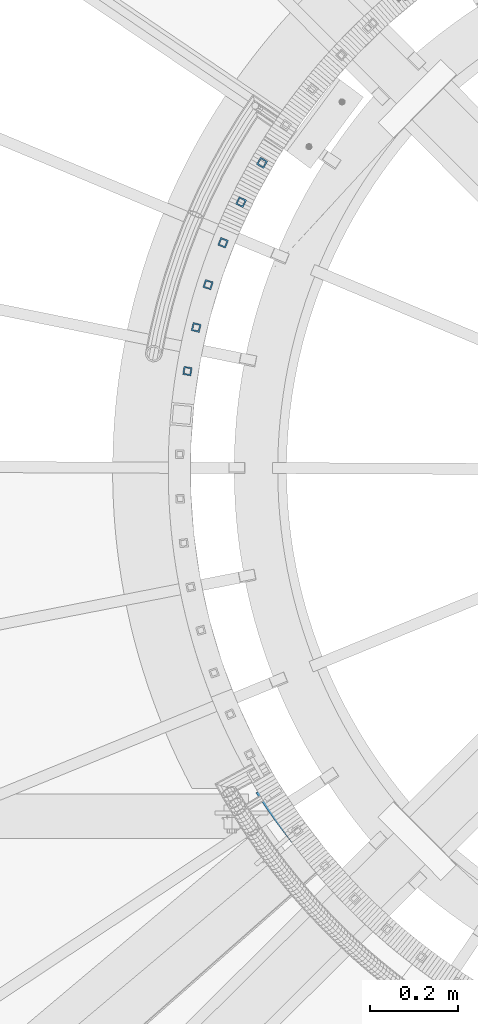
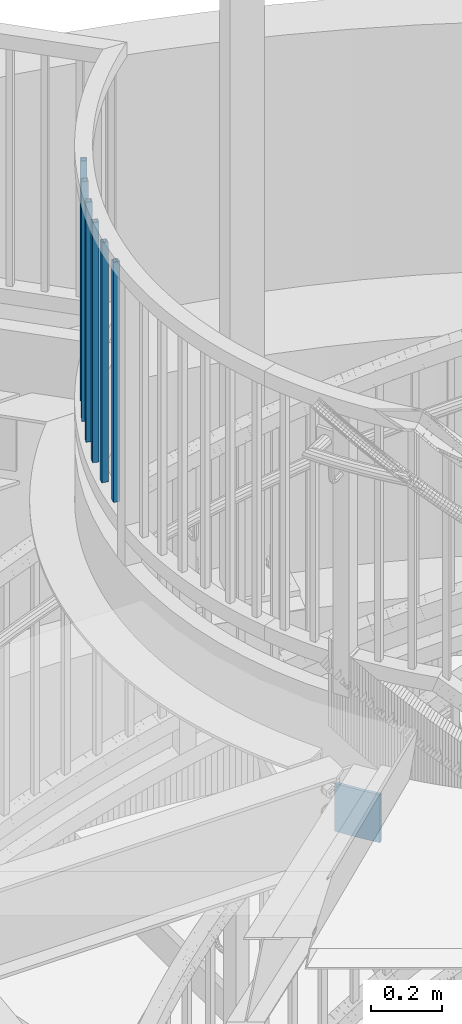
# One storey, part 476 of 975: 7 beams.
"""IFC2X3 building model written with IfcOpenShell, lengths in millimetres."""

import ifcopenshell
import ifcopenshell.guid

model = None  # the IFC model being written
_history = None  # IfcOwnerHistory: only IFC2X3 demands one
_inside = {}  # id of a spatial element -> (the spatial element, [elements in it])
_under = {}  # id of a project, library or spatial element -> (it, [spatial elements below it])
_declared = {}  # id of a project -> (the project, [libraries it declares])
_typed = {}  # id of a type object -> (the type object, [elements of that type])
_made_of = {}  # id of a material, layer set ... -> (it, [elements and type objects made of it])


def new_model(schema):
    """Start an empty IFC model of exactly this schema.

    Asked for "IFC4X3", IfcOpenShell would pick the latest addendum, in which some entities
    have other attributes; the version numbers below select the first issue.
    IFC2X3 requires an IfcOwnerHistory on every rooted entity: one is made here for all.
    """
    global model, _history
    if schema == "IFC4X3":
        model = ifcopenshell.file(schema_version=(4, 3, 0, 0))
    else:
        model = ifcopenshell.file(schema=schema)
    _inside.clear()
    _under.clear()
    _declared.clear()
    _typed.clear()
    _made_of.clear()
    _history = None
    if model.schema == "IFC2X3":
        org = make("IfcOrganization", Name="unknown")
        user = make(
            "IfcPersonAndOrganization",
            ThePerson=make("IfcPerson", FamilyName="unknown"),
            TheOrganization=org,
        )
        app = make(
            "IfcApplication",
            ApplicationDeveloper=org,
            Version="unknown",
            ApplicationFullName="unknown",
            ApplicationIdentifier="unknown",
        )
        _history = make(
            "IfcOwnerHistory",
            OwningUser=user,
            OwningApplication=app,
            ChangeAction="ADDED",
            CreationDate=0,
        )
    return model


def make(cls, **values):
    """One entity of the class cls with the attributes given. An attribute that is None is left unset."""
    return model.create_entity(
        cls, **{name: value for name, value in values.items() if value is not None}
    )


def rooted(cls, **values):
    """An entity with a GlobalId (a new one), such as an element, a storey or a relation."""
    return make(cls, GlobalId=ifcopenshell.guid.new(), OwnerHistory=_history, **values)


def si_unit(unit_type, name, prefix=None):
    """IfcSIUnit, for example si_unit("LENGTHUNIT", "METRE", prefix="MILLI")."""
    return make("IfcSIUnit", UnitType=unit_type, Prefix=prefix, Name=name)


def assignment(units):
    """IfcUnitAssignment: the units of a project."""
    return None if units is None else make("IfcUnitAssignment", Units=units)


def point(xyz):
    """IfcCartesianPoint."""
    return None if xyz is None else make("IfcCartesianPoint", Coordinates=xyz)


def direction(xyz):
    """IfcDirection."""
    return None if xyz is None else make("IfcDirection", DirectionRatios=xyz)


def frame(location, z_axis=None, x_axis=None):
    """IfcAxis2Placement3D, a coordinate frame: its origin and axes. An axis left out is left unset."""
    return make(
        "IfcAxis2Placement3D",
        Location=point(location),
        Axis=direction(z_axis),
        RefDirection=direction(x_axis),
    )


def origin_with_axes():
    """The frame at (0, 0, 0) with the z axis (0, 0, 1) and the x axis (1, 0, 0) written out."""
    return frame((0.0, 0.0, 0.0), z_axis=(0.0, 0.0, 1.0), x_axis=(1.0, 0.0, 0.0))


def place(relative_to, where):
    """IfcLocalPlacement: puts the frame where relative to a parent placement (None: the world)."""
    return make(
        "IfcLocalPlacement", PlacementRelTo=relative_to, RelativePlacement=where
    )


def context(
    kind, dimensions, precision=None, world=None, true_north=None, identifier=None
):
    """IfcGeometricRepresentationContext, for example the 3D "Model" context."""
    return make(
        "IfcGeometricRepresentationContext",
        ContextIdentifier=identifier,
        ContextType=kind,
        CoordinateSpaceDimension=dimensions,
        Precision=precision,
        WorldCoordinateSystem=world,
        TrueNorth=true_north,
    )


def subcontext(parent, identifier, kind, view, scale=None):
    """IfcGeometricRepresentationSubContext, for example "Body" below "Model"."""
    return make(
        "IfcGeometricRepresentationSubContext",
        ContextIdentifier=identifier,
        ContextType=kind,
        ParentContext=parent,
        TargetScale=scale,
        TargetView=view,
    )


def project(units=None, contexts=None):
    """IfcProject with its units and contexts."""
    return rooted(
        "IfcProject",
        Name="project",
        RepresentationContexts=contexts,
        UnitsInContext=assignment(units),
    )


def spatial(cls, under=None, at=None, **own):
    """A site, building, storey or space (cls), placed at a placement, below another one or the project."""
    s = rooted(cls, ObjectPlacement=at, **own)
    if under is not None:
        _under.setdefault(under.id(), (under, []))[1].append(s)
    return s


def faces_of(points, faces, orient=None, outer=None):
    """IfcFace entities. A face is a list of loops; a loop is a list of indices into points, from 0.

    orient and outer hold one flag for each loop. By default every Orientation is true, the
    first loop of a face is its IfcFaceOuterBound and the others are IfcFaceBound.
    """
    made = []
    for i, loops in enumerate(faces):
        bounds = []
        for j, loop in enumerate(loops):
            is_outer = j == 0 if outer is None else outer[i][j]
            bounds.append(
                make(
                    "IfcFaceOuterBound" if is_outer else "IfcFaceBound",
                    Bound=make("IfcPolyLoop", Polygon=[points[k] for k in loop]),
                    Orientation=True if orient is None else orient[i][j],
                )
            )
        made.append(make("IfcFace", Bounds=bounds))
    return made


def faceted_brep(points, faces, orient=None, outer=None, voids=None):
    """IfcFacetedBrep: a solid bounded by flat faces; with voids (closed shells), ...WithVoids."""
    shared = [point(p) for p in points]
    hull = make("IfcClosedShell", CfsFaces=faces_of(shared, faces, orient, outer))
    if voids is None:
        return make("IfcFacetedBrep", Outer=hull)
    return make(
        "IfcFacetedBrepWithVoids",
        Outer=hull,
        Voids=[
            make(cls, CfsFaces=faces_of(shared, fs, o, b)) for cls, fs, o, b in voids
        ],
    )


def shape(context_of_items, identifier, shape_type, items):
    """IfcShapeRepresentation: the items that make up one representation, for example the "Body"."""
    return make(
        "IfcShapeRepresentation",
        ContextOfItems=context_of_items,
        RepresentationIdentifier=identifier,
        RepresentationType=shape_type,
        Items=items,
    )


def material(Name=None, Category=None):
    """IfcMaterial."""
    return make("IfcMaterial", Name=Name, Category=Category)


def made_of(thing, what):
    """Note that an element or type object is made of a material, layer set ...; save() writes the relation."""
    if what is not None:
        _made_of.setdefault(what.id(), (what, []))[1].append(thing)
    return thing


def type_object(cls, material=None, **own):
    """A type object (cls), such as IfcWallType, which elements share."""
    return made_of(rooted(cls, **own), material)


def element(
    cls,
    number,
    at=None,
    inside=None,
    cuts=None,
    type_object=None,
    material=None,
    context=None,
    identifier="Body",
    shape_type=None,
    held_by="IfcProductDefinitionShape",
    body=None,
    shapes=None,
    **own,
):
    """One element of the class cls, such as IfcWall. Its Tag is "e" and its number.

    at: its placement. inside: the storey or other place that contains it. cuts: it is an
    opening in that element (IfcRelVoidsElement). A single representation is given by context,
    identifier, shape_type and body (its items); several are given by shapes. held_by: the class
    of the entity that holds the representations. save() writes the other relations.
    """
    e = rooted(cls, Tag="e%d" % number, ObjectPlacement=at, **own)
    if body is not None:
        shapes = [shape(context, identifier, shape_type, body)]
    if shapes is not None:
        e.Representation = make(held_by, Representations=shapes)
    if inside is not None:
        _inside.setdefault(inside.id(), (inside, []))[1].append(e)
    if cuts is not None:
        rooted(
            "IfcRelVoidsElement", RelatingBuildingElement=cuts, RelatedOpeningElement=e
        )
    if type_object is not None:
        _typed.setdefault(type_object.id(), (type_object, []))[1].append(e)
    return made_of(e, material)


def aggregate(whole, parts):
    """IfcRelAggregates: a whole, such as a stair, and the parts it consists of."""
    return rooted("IfcRelAggregates", RelatingObject=whole, RelatedObjects=parts)


def save(model, path):
    """Write the relations noted so far, then the file.

    IfcRelAggregates (storeys below a building ...), IfcRelContainedInSpatialStructure (elements
    in a storey), IfcRelDefinesByType, IfcRelAssociatesMaterial and IfcRelDeclares: one each for
    every whole, place, type object, material and project.
    """
    for whole, parts in _under.values():
        aggregate(whole, parts)
    for where, things in _inside.values():
        rooted(
            "IfcRelContainedInSpatialStructure",
            RelatedElements=things,
            RelatingStructure=where,
        )
    for kind, things in _typed.values():
        rooted("IfcRelDefinesByType", RelatedObjects=things, RelatingType=kind)
    for what, things in _made_of.values():
        rooted("IfcRelAssociatesMaterial", RelatedObjects=things, RelatingMaterial=what)
    for by, libraries in _declared.values():
        rooted("IfcRelDeclares", RelatingContext=by, RelatedDefinitions=libraries)
    model.write(path)


model = new_model("IFC2X3")

# Units and contexts
model_context = context("Model", 3, precision=1e-05, world=origin_with_axes())
body_context = subcontext(model_context, "Body", "Model", "MODEL_VIEW")
ifc_project = project(units=[si_unit("LENGTHUNIT", "METRE", prefix="MILLI"), si_unit("AREAUNIT", "SQUARE_METRE"), si_unit("VOLUMEUNIT", "CUBIC_METRE"), si_unit("MASSUNIT", "GRAM", prefix="KILO"), si_unit("TIMEUNIT", "SECOND"), si_unit("PLANEANGLEUNIT", "RADIAN"), si_unit("SOLIDANGLEUNIT", "STERADIAN"), si_unit("THERMODYNAMICTEMPERATUREUNIT", "DEGREE_CELSIUS"), si_unit("LUMINOUSINTENSITYUNIT", "LUMEN")], contexts=[model_context])

# Site, building, storey
site_placement = place(None, origin_with_axes())
site = spatial("IfcSite", under=ifc_project, at=site_placement, CompositionType="ELEMENT")
building_placement = place(site_placement, origin_with_axes())
building = spatial("IfcBuilding", under=site, at=building_placement, Name="Undefined", CompositionType="ELEMENT")
storey_placement = place(building_placement, origin_with_axes())
storey = spatial("IfcBuildingStorey", under=building, at=storey_placement, Name="Undefined", CompositionType="ELEMENT", Elevation=0.0)

# Beams
ifc_material_1 = material()
beam_type_1 = type_object("IfcBeamType", Name="HSS3/4X3/4X.120_TUBES", PredefinedType="NOTDEFINED")
for number, where, z_axis, x_axis, name in (
    (1, (33526.2036362161, 4104.66952004517, 4279.9), (-0.864920583602522, 0.501908740769348, 0.0), (0.0, 0.0, 1.0), "PICKET"),
    (2, (33478.4562580799, 4015.03159745493, 4279.9), (-0.899104743728722, 0.437733548867926, 0.0), (0.0, 0.0, 1.0), "PICKET"),
    (3, (33437.34853009, 3922.16112859848, 4279.9), (-0.928535325998714, 0.371244054999486, 0.0), (0.0, 0.0, 1.0), "PICKET"),
    (4, (33403.0977892671, 3826.54912077631, 4279.9), (-0.953056730716079, 0.302791789909797, 0.0), (0.0, 0.0, 1.0), "PICKET"),
    (5, (33375.8851197102, 3728.70107582034, 4279.9), (-0.972539313394312, 0.232738660094363, 0.0), (0.0, 0.0, 1.0), "PICKET"),
    (6, (33355.8543951191, 3629.13431752426, 4279.9), (-0.986880069056733, 0.161455038009282, 0.0), (0.0, 0.0, 1.0), "PICKET"),
):
    element("IfcBeam", number, at=place(storey_placement, frame(where, z_axis=z_axis, x_axis=x_axis)), inside=storey, type_object=beam_type_1, material=ifc_material_1, Name=name, ObjectType="HSS3/4X3/4X.120_TUBES", context=body_context, shape_type="Brep", body=[
        faceted_brep([(0.0, 6.34999999998763, -6.34999999998763), (0.0, -6.35000000000582, -6.34999999998763), (825.49997943247, -6.35000000000582, -6.34999999998763), (825.49997943247, 6.34999999998763, -6.34999999998763), (0.0, -6.34999999998763, 6.34999999998763), (825.49997943247, -6.34999999998763, 6.34999999998763), (0.0, 6.35000000000946, 6.34999999998763), (825.49997943247, 6.35000000000946, 6.34999999998763), (0.0, 9.52499999997963, -9.52499999997963), (0.0, 9.52500000000873, 9.5249999999869), (825.49997943247, 9.52500000000873, 9.5249999999869), (825.49997943247, 9.52499999997963, -9.52499999997963), (0.0, -9.52499999997963, 9.52499999998327), (825.49997943247, -9.52499999997963, 9.52499999998327), (0.0, -9.52500000000873, -9.5249999999869), (825.49997943247, -9.52500000000873, -9.5249999999869)], [[[0, 1, 2, 3]], [[1, 4, 5, 2]], [[4, 6, 7, 5]], [[6, 0, 3, 7]], [[8, 9, 10, 11]], [[9, 12, 13, 10]], [[12, 14, 15, 13]], [[14, 8, 11, 15]], [[13, 15, 11, 10], [5, 7, 3, 2]], [[14, 12, 9, 8], [6, 4, 1, 0]]]),
    ])
ifc_material_2 = material(Name="STEEL/A36")
beam_type_2 = type_object("IfcBeamType", PredefinedType="NOTDEFINED")
beam_placement = place(storey_placement, frame((33598.4438526061, 2554.79808914706, 3752.87588265217), z_axis=(0.0, 0.0, 1.0), x_axis=(-0.58585209482599, 0.810417992759292, 0.0)))
element("IfcBeam", 7, at=beam_placement, inside=storey, type_object=beam_type_2, material=ifc_material_2, Name="PLATE", context=body_context, shape_type="Brep", body=[
    faceted_brep([(-0.241980966413394, 4.75634854293821, -82.5500000000002), (-0.241980966413394, 4.75634854293821, 82.5500000000002), (2.14033713367462, 4.87549213239618, 82.5500000000002), (2.14033713367462, 4.87549213239618, -82.5500000000002), (0.241980966406118, -4.75634854294913, 82.5500000000002), (0.241980966406118, -4.75634854294913, -82.5500000000002), (2.60790699908466, -4.63802474734985, -82.5500000000002), (2.60790699908466, -4.63802474734985, 82.5500000000002), (4.52285699369168, 4.99053056750927, 82.5500000000002), (4.52285699369168, 4.99053056750927, -82.5500000000002), (4.97403340342862, -4.52377785967474, -82.5500000000002), (4.97403340342862, -4.52377785967474, 82.5500000000002), (6.9055715397335, 5.10146350670766, 82.5500000000002), (6.9055715397335, 5.10146350670766, -82.5500000000002), (7.34035315422079, -4.41360821913986, -82.5500000000002), (7.34035315422079, -4.41360821913986, 82.5500000000002), (9.28847369732466, 5.20829062062694, 82.5500000000002), (9.28847369732466, 5.20829062062694, -82.5500000000002), (9.70685922566554, -4.30751615283589, -82.5500000000002), (9.70685922566554, -4.30751615283589, 82.5500000000002), (11.6715563914368, 5.31101159209356, 82.5500000000002), (11.6715563914368, 5.31101159209356, -82.5500000000002), (12.0735445913961, -4.20550197577904, -82.5500000000002), (12.0735445913961, -4.20550197577904, 82.5500000000002), (14.0548125464848, 5.40962611609939, 82.5500000000002), (14.0548125464848, 5.40962611609939, -82.5500000000002), (14.4404022245362, -4.10756599083834, -82.5500000000002), (14.4404022245362, -4.10756599083834, 82.5500000000002), (16.4382350863889, 5.50413389987807, 82.5500000000002), (16.4382350863889, 5.50413389987807, -82.5500000000002), (16.8074250976861, -4.01370848880106, -82.5500000000002), (16.8074250976861, -4.01370848880106, 82.5500000000002), (18.8218169345746, 5.59453466281411, 82.5500000000002), (18.8218169345746, 5.59453466281411, -82.5500000000002), (19.1746061829544, -3.92392974834729, -82.5500000000002), (19.1746061829544, -3.92392974834729, 82.5500000000002), (21.2055510139799, 5.6808281364938, 82.5500000000002), (21.2055510139799, 5.6808281364938, -82.5500000000002), (21.5419384519882, -3.83823003602811, -82.5500000000002), (21.5419384519882, -3.83823003602811, 82.5500000000002), (23.5894302471097, 5.76301406471612, 82.5500000000002), (23.5894302471097, 5.76301406471612, -82.5500000000002), (23.9094148759759, -3.75660960628738, -82.5500000000002), (23.9094148759759, -3.75660960628738, 82.5500000000002), (25.9734475560181, 5.84109220345999, 82.5500000000002), (25.9734475560181, 5.84109220345999, -82.5500000000002), (26.2770284256876, -3.67906870147999, -82.5500000000002), (26.2770284256876, -3.67906870147999, 82.5500000000002), (28.357595862366, 5.91506232090251, 82.5500000000002), (28.357595862366, 5.91506232090251, -82.5500000000002), (28.6447720714787, -3.60560755181359, -82.5500000000002), (28.6447720714787, -3.60560755181359, 82.5500000000002), (30.7418680874143, 5.98492419742615, 82.5500000000002), (30.7418680874143, 5.98492419742615, -82.5500000000002), (31.0126387833188, -3.53622637541048, -82.5500000000002), (31.0126387833188, -3.53622637541048, 82.5500000000002), (33.1262571520601, 6.05067762559702, 82.5500000000002), (33.1262571520601, 6.05067762559702, -82.5500000000002), (33.3806215308214, -3.47092537826757, -82.5500000000002), (33.3806215308214, -3.47092537826757, 82.5500000000002), (35.5107559768585, 6.11232241019388, 82.5500000000002), (35.5107559768585, 6.11232241019388, -82.5500000000002), (35.7487132832466, -3.40970475426366, -82.5500000000002), (35.7487132832466, -3.40970475426366, 82.5500000000002), (37.8953574820298, 6.1698583681864, 82.5500000000002), (37.8953574820298, 6.1698583681864, -82.5500000000002), (38.1169070095275, -3.35256468517036, -82.5500000000002), (38.1169070095275, -3.35256468517036, 82.5500000000002), (40.2800545874961, 6.22328532874599, 82.5500000000002), (40.2800545874961, 6.22328532874599, -82.5500000000002), (40.4851956783059, -3.29950534064847, -82.5500000000002), (40.4851956783059, -3.29950534064847, 82.5500000000002), (42.6648402128922, 6.27260313324587, 82.5500000000002), (42.6648402128922, 6.27260313324587, -82.5500000000002), (42.853572257929, -3.25052687822972, -82.5500000000002), (42.853572257929, -3.25052687822972, 82.5500000000002), (45.049707277587, 6.31781163525011, 82.5500000000002), (45.049707277587, 6.31781163525011, -82.5500000000002), (45.2220297164931, -3.20562944333869, -82.5500000000002), (45.2220297164931, -3.20562944333869, 82.5500000000002), (47.4346487007169, 6.35891070053549, 82.5500000000002), (47.4346487007169, 6.35891070053549, -82.5500000000002), (47.5905610218506, -3.1648131692782, -82.5500000000002), (47.5905610218506, -3.1648131692782, 82.5500000000002), (49.819657401189, 6.39590020708056, 82.5500000000002), (49.819657401189, 6.39590020708056, -82.5500000000002), (49.9591591416392, -3.12807817722933, -82.5500000000002), (49.9591591416392, -3.12807817722933, 82.5500000000002), (52.2047262977212, 6.4287800450511, 82.5500000000002), (52.2047262977212, 6.4287800450511, -82.5500000000002), (52.3278170432859, -3.09542457626594, -82.5500000000002), (52.3278170432859, -3.09542457626594, 82.5500000000002), (54.5898483088276, 6.45755011682559, 82.5500000000002), (54.5898483088276, 6.45755011682559, -82.5500000000002), (54.6965276940537, -3.06685246334018, -82.5500000000002), (54.6965276940537, -3.06685246334018, 82.5500000000002), (56.9750163529061, 6.48221033699156, 82.5500000000002), (56.9750163529061, 6.48221033699156, -82.5500000000002), (57.0652840610419, -3.04236192328608, -82.5500000000002), (57.0652840610419, -3.04236192328608, 82.5500000000002), (59.3602233481761, 6.50276063232377, 82.5500000000002), (59.3602233481761, 6.50276063232377, -82.5500000000002), (59.4340791112154, -3.02195302880864, -82.5500000000002), (59.4340791112154, -3.02195302880864, 82.5500000000002), (61.7454622127661, 6.51920094180605, 82.5500000000002), (61.7454622127661, 6.51920094180605, -82.5500000000002), (61.8029058114262, -3.00562584051659, -82.5500000000002), (61.8029058114262, -3.00562584051659, 82.5500000000002), (64.1307258647066, 6.53153121663127, 82.5500000000002), (64.1307258647066, 6.53153121663127, -82.5500000000002), (64.1717571284207, -2.99338040688235, -82.5500000000002), (64.1717571284207, -2.99338040688235, 82.5500000000002), (66.5160072219369, 6.53975142017953, 82.5500000000002), (66.5160072219369, 6.53975142017953, -82.5500000000002), (66.5406260288946, -2.98521676426026, -82.5500000000002), (66.5406260288946, -2.98521676426026, 82.5500000000002), (68.9012992023781, 6.54386152805819, 82.5500000000002), (68.9012992023781, 6.54386152805819, -82.5500000000002), (68.9095054794743, -2.9811349368938, -82.5500000000002), (68.9095054794743, -2.9811349368938, 82.5500000000002), (71.2865947238861, 6.54386152805455, 82.5500000000002), (71.2865947238861, 6.54386152805455, -82.5500000000002), (71.2783884467608, -2.9811349368938, -82.5500000000002), (71.2783884467608, -2.9811349368938, 82.5500000000002), (73.6718867043237, 6.53975142016861, 82.5500000000002), (73.6718867043237, 6.53975142016861, -82.5500000000002), (73.6472678973441, -2.98521676427117, -82.5500000000002), (73.6472678973441, -2.98521676427117, 82.5500000000002), (76.0571680615612, 6.53153121661308, 82.5500000000002), (76.0571680615612, 6.53153121661308, -82.5500000000002), (76.0161367978144, -2.99338040690054, -82.5500000000002), (76.0161367978144, -2.99338040690054, 82.5500000000002), (78.4424317134944, 6.51920094177694, 82.5500000000002), (78.4424317134944, 6.51920094177694, -82.5500000000002), (78.3849881148162, -3.00562584054205, -82.5500000000002), (78.3849881148162, -3.00562584054205, 82.5500000000002), (80.8276705780881, 6.50276063229467, 82.5500000000002), (80.8276705780881, 6.50276063229467, -82.5500000000002), (80.7538148150197, -3.02195302884502, -82.5500000000002), (80.7538148150197, -3.02195302884502, 82.5500000000002), (83.2128775733581, 6.48221033695154, 82.5500000000002), (83.2128775733581, 6.48221033695154, -82.5500000000002), (83.1226098651969, -3.04236192331882, -82.5500000000002), (83.1226098651969, -3.04236192331882, 82.5500000000002), (85.5980456174293, 6.45755011678193, 82.5500000000002), (85.5980456174293, 6.45755011678193, -82.5500000000002), (85.4913662321815, -3.06685246338384, -82.5500000000002), (85.4913662321815, -3.06685246338384, 82.5500000000002), (87.9831676285503, 6.42878004500017, 82.5500000000002), (87.9831676285503, 6.42878004500017, -82.5500000000002), (87.8600768829492, -3.09542457631687, -82.5500000000002), (87.8600768829492, -3.09542457631687, 82.5500000000002), (90.3682365250752, 6.39590020702235, 82.5500000000002), (90.3682365250752, 6.39590020702235, -82.5500000000002), (90.2287347845995, -3.1280781772839, -82.5500000000002), (90.2287347845995, -3.1280781772839, 82.5500000000002), (92.7532452255473, 6.35891070047001, 82.5500000000002), (92.7532452255473, 6.35891070047001, -82.5500000000002), (92.5973329043845, -3.16481316934005, -82.5500000000002), (92.5973329043845, -3.16481316934005, 82.5500000000002), (95.1381866486772, 6.31781163517371, 82.5500000000002), (95.1381866486772, 6.31781163517371, -82.5500000000002), (94.9658642097456, -3.20562944340782, -82.5500000000002), (94.9658642097456, -3.20562944340782, 82.5500000000002), (97.5230537133721, 6.27260313316583, 82.5500000000002), (97.5230537133721, 6.27260313316583, -82.5500000000002), (97.3343216683097, -3.25052687831339, -82.5500000000002), (97.3343216683097, -3.25052687831339, 82.5500000000002), (99.9078393387681, 6.22328532865868, 82.5500000000002), (99.9078393387681, 6.22328532865868, -82.5500000000002), (99.7026982479329, -3.29950534073578, -82.5500000000002), (99.7026982479329, -3.29950534073578, 82.5500000000002), (102.292536444234, 6.16985836809545, 82.5500000000002), (102.292536444234, 6.16985836809545, -82.5500000000002), (102.070986916708, -3.35256468526131, -82.5500000000002), (102.070986916708, -3.35256468526131, 82.5500000000002), (104.677137949402, 6.11232241009202, 82.5500000000002), (104.677137949402, 6.11232241009202, -82.5500000000002), (104.439180642992, -3.40970475435824, -82.5500000000002), (104.439180642992, -3.40970475435824, 82.5500000000002), (107.061636774204, 6.05067762549515, 82.5500000000002), (107.061636774204, 6.05067762549515, -82.5500000000002), (106.807272395414, -3.47092537836579, -82.5500000000002), (106.807272395414, -3.47092537836579, 82.5500000000002), (109.44602583885, 5.98492419731338, 82.5500000000002), (109.44602583885, 5.98492419731338, -82.5500000000002), (109.175255142913, -3.53622637552326, -82.5500000000002), (109.175255142913, -3.53622637552326, 82.5500000000002), (111.830298063895, 5.91506232078245, 82.5500000000002), (111.830298063895, 5.91506232078245, -82.5500000000002), (111.54312185476, -3.60560755192637, -82.5500000000002), (111.54312185476, -3.60560755192637, 82.5500000000002), (114.214446370243, 5.84109220333266, 82.5500000000002), (114.214446370243, 5.84109220333266, -82.5500000000002), (113.910865500548, -3.67906870160368, -82.5500000000002), (113.910865500548, -3.67906870160368, 82.5500000000002), (116.598463679151, 5.76301406458151, 82.5500000000002), (116.598463679151, 5.76301406458151, -82.5500000000002), (116.278479050263, -3.75660960641835, -82.5500000000002), (116.278479050263, -3.75660960641835, 82.5500000000002), (118.982342912281, 5.6808281363592, 82.5500000000002), (118.982342912281, 5.6808281363592, -82.5500000000002), (118.645955474247, -3.83823003616635, -82.5500000000002), (118.645955474247, -3.83823003616635, 82.5500000000002), (121.366076991686, 5.59453466266496, 82.5500000000002), (121.366076991686, 5.59453466266496, -82.5500000000002), (121.013287743284, -3.92392974849281, -82.5500000000002), (121.013287743284, -3.92392974849281, 82.5500000000002), (123.749658839868, 5.50413389972891, 82.5500000000002), (123.749658839868, 5.50413389972891, -82.5500000000002), (123.380468828549, -4.01370848896113, -82.5500000000002), (123.380468828549, -4.01370848896113, 82.5500000000002), (126.133081379776, 5.40962611594296, 82.5500000000002), (126.133081379776, 5.40962611594296, -82.5500000000002), (125.747491701695, -4.10756599099841, -82.5500000000002), (125.747491701695, -4.10756599099841, 82.5500000000002), (128.51633753482, 5.31101159191894, 82.5500000000002), (128.51633753482, 5.31101159191894, -82.5500000000002), (128.114349334839, -4.20550197594275, -82.5500000000002), (128.114349334839, -4.20550197594275, 82.5500000000002), (130.899420228936, 5.20829062045595, 82.5500000000002), (130.899420228936, 5.20829062045595, -82.5500000000002), (130.48103470057, -4.30751615301051, -82.5500000000002), (130.48103470057, -4.30751615301051, 82.5500000000002), (133.282322386527, 5.10146350653304, 82.5500000000002), (133.282322386527, 5.10146350653304, -82.5500000000002), (132.847540772007, -4.41360821931812, -82.5500000000002), (132.847540772007, -4.41360821931812, 82.5500000000002), (135.665036932569, 4.99053056732373, 82.5500000000002), (135.665036932569, 4.99053056732373, -82.5500000000002), (135.213860522803, -4.52377785986027, -82.5500000000002), (135.213860522803, -4.52377785986027, 82.5500000000002), (138.047556792582, 4.87549213220336, 82.5500000000002), (138.047556792582, 4.87549213220336, -82.5500000000002), (137.579986927154, -4.63802474753902, -82.5500000000002), (137.579986927154, -4.63802474753902, 82.5500000000002), (140.429874892674, 4.75634854273449, 82.5500000000002), (140.429874892674, 4.75634854273449, -82.5500000000002), (139.945912959825, -4.75634854314922, 82.5500000000002), (139.945912959825, -4.75634854314922, -82.5500000000002)], [[[0, 1, 2, 3]], [[4, 5, 6, 7]], [[5, 4, 1, 0]], [[3, 2, 8, 9]], [[7, 6, 10, 11]], [[9, 8, 12, 13]], [[11, 10, 14, 15]], [[13, 12, 16, 17]], [[15, 14, 18, 19]], [[17, 16, 20, 21]], [[19, 18, 22, 23]], [[21, 20, 24, 25]], [[23, 22, 26, 27]], [[25, 24, 28, 29]], [[27, 26, 30, 31]], [[29, 28, 32, 33]], [[31, 30, 34, 35]], [[33, 32, 36, 37]], [[35, 34, 38, 39]], [[37, 36, 40, 41]], [[39, 38, 42, 43]], [[41, 40, 44, 45]], [[43, 42, 46, 47]], [[45, 44, 48, 49]], [[47, 46, 50, 51]], [[49, 48, 52, 53]], [[51, 50, 54, 55]], [[53, 52, 56, 57]], [[55, 54, 58, 59]], [[57, 56, 60, 61]], [[59, 58, 62, 63]], [[61, 60, 64, 65]], [[63, 62, 66, 67]], [[65, 64, 68, 69]], [[67, 66, 70, 71]], [[69, 68, 72, 73]], [[71, 70, 74, 75]], [[73, 72, 76, 77]], [[75, 74, 78, 79]], [[77, 76, 80, 81]], [[79, 78, 82, 83]], [[81, 80, 84, 85]], [[83, 82, 86, 87]], [[85, 84, 88, 89]], [[87, 86, 90, 91]], [[89, 88, 92, 93]], [[91, 90, 94, 95]], [[93, 92, 96, 97]], [[95, 94, 98, 99]], [[97, 96, 100, 101]], [[99, 98, 102, 103]], [[101, 100, 104, 105]], [[103, 102, 106, 107]], [[105, 104, 108, 109]], [[107, 106, 110, 111]], [[109, 108, 112, 113]], [[111, 110, 114, 115]], [[113, 112, 116, 117]], [[115, 114, 118, 119]], [[117, 116, 120, 121]], [[119, 118, 122, 123]], [[121, 120, 124, 125]], [[123, 122, 126, 127]], [[125, 124, 128, 129]], [[127, 126, 130, 131]], [[129, 128, 132, 133]], [[131, 130, 134, 135]], [[133, 132, 136, 137]], [[135, 134, 138, 139]], [[137, 136, 140, 141]], [[139, 138, 142, 143]], [[141, 140, 144, 145]], [[143, 142, 146, 147]], [[145, 144, 148, 149]], [[147, 146, 150, 151]], [[149, 148, 152, 153]], [[151, 150, 154, 155]], [[153, 152, 156, 157]], [[155, 154, 158, 159]], [[157, 156, 160, 161]], [[159, 158, 162, 163]], [[161, 160, 164, 165]], [[163, 162, 166, 167]], [[165, 164, 168, 169]], [[167, 166, 170, 171]], [[169, 168, 172, 173]], [[171, 170, 174, 175]], [[173, 172, 176, 177]], [[175, 174, 178, 179]], [[177, 176, 180, 181]], [[179, 178, 182, 183]], [[181, 180, 184, 185]], [[183, 182, 186, 187]], [[185, 184, 188, 189]], [[187, 186, 190, 191]], [[189, 188, 192, 193]], [[191, 190, 194, 195]], [[193, 192, 196, 197]], [[195, 194, 198, 199]], [[197, 196, 200, 201]], [[199, 198, 202, 203]], [[201, 200, 204, 205]], [[203, 202, 206, 207]], [[205, 204, 208, 209]], [[207, 206, 210, 211]], [[209, 208, 212, 213]], [[211, 210, 214, 215]], [[213, 212, 216, 217]], [[215, 214, 218, 219]], [[217, 216, 220, 221]], [[219, 218, 222, 223]], [[221, 220, 224, 225]], [[223, 222, 226, 227]], [[225, 224, 228, 229]], [[227, 226, 230, 231]], [[229, 228, 232, 233]], [[231, 230, 234, 235]], [[233, 232, 236, 237]], [[232, 228, 224, 220, 216, 212, 208, 204, 200, 196, 192, 188, 184, 180, 176, 172, 168, 164, 160, 156, 152, 148, 144, 140, 136, 132, 128, 124, 120, 116, 112, 108, 104, 100, 96, 92, 88, 84, 80, 76, 72, 68, 64, 60, 56, 52, 48, 44, 40, 36, 32, 28, 24, 20, 16, 12, 8, 2, 1, 4, 7, 11, 15, 19, 23, 27, 31, 35, 39, 43, 47, 51, 55, 59, 63, 67, 71, 75, 79, 83, 87, 91, 95, 99, 103, 107, 111, 115, 119, 123, 127, 131, 135, 139, 143, 147, 151, 155, 159, 163, 167, 171, 175, 179, 183, 187, 191, 195, 199, 203, 207, 211, 215, 219, 223, 227, 231, 235, 238, 236]], [[235, 234, 239, 238]], [[234, 230, 226, 222, 218, 214, 210, 206, 202, 198, 194, 190, 186, 182, 178, 174, 170, 166, 162, 158, 154, 150, 146, 142, 138, 134, 130, 126, 122, 118, 114, 110, 106, 102, 98, 94, 90, 86, 82, 78, 74, 70, 66, 62, 58, 54, 50, 46, 42, 38, 34, 30, 26, 22, 18, 14, 10, 6, 5, 0, 3, 9, 13, 17, 21, 25, 29, 33, 37, 41, 45, 49, 53, 57, 61, 65, 69, 73, 77, 81, 85, 89, 93, 97, 101, 105, 109, 113, 117, 121, 125, 129, 133, 137, 141, 145, 149, 153, 157, 161, 165, 169, 173, 177, 181, 185, 189, 193, 197, 201, 205, 209, 213, 217, 221, 225, 229, 233, 237, 239]], [[238, 239, 237, 236]]]),
])

save(model, "model.ifc")
